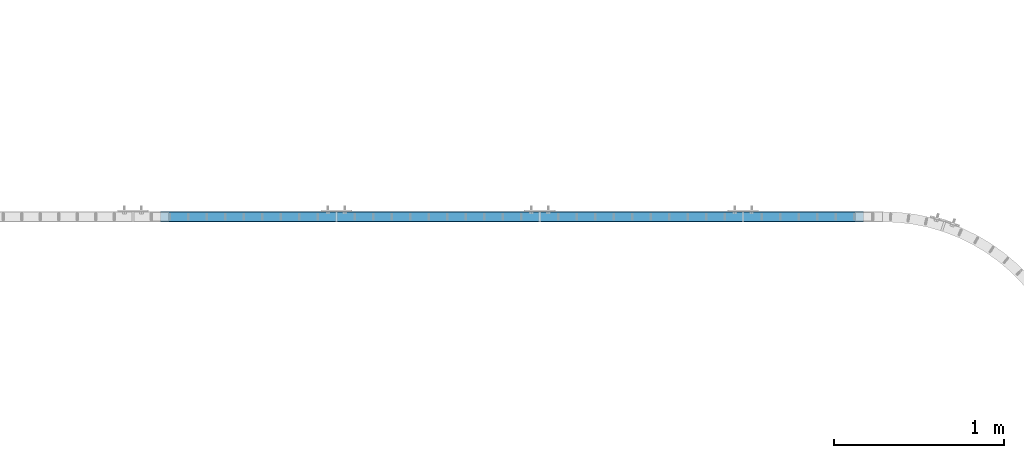
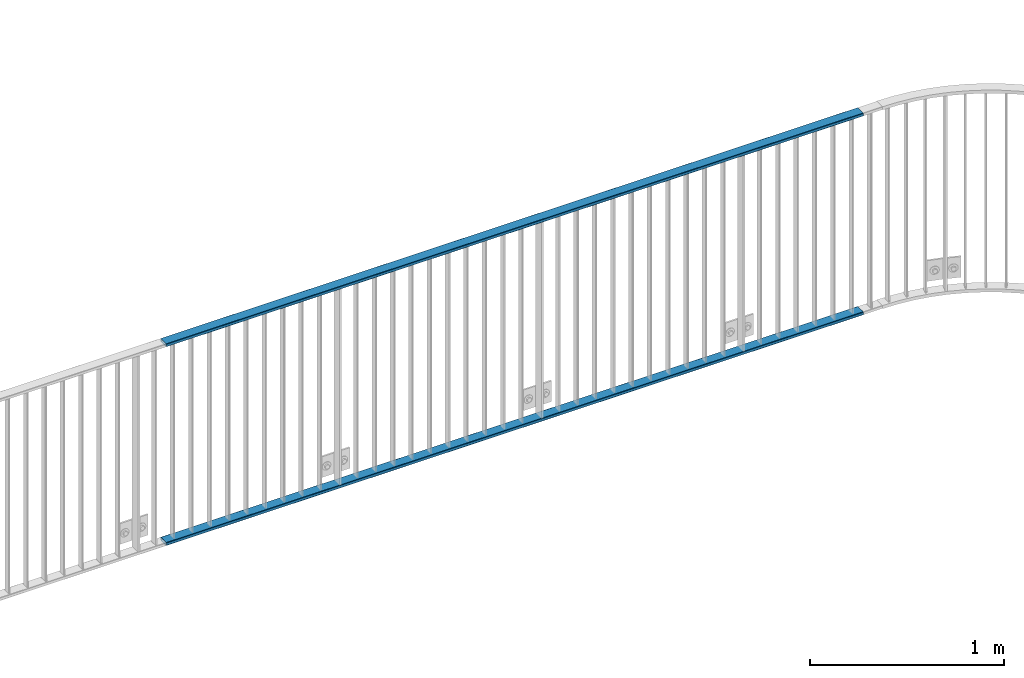
# One storey, part 9 of 156: 2 beams, 1 element without a shape of its own.
"""IFC2X3 building model written with IfcOpenShell, lengths in millimetres."""

from ifc_helpers import new_model, si_unit, frame, origin_with_axes, origin_2d_with_axis, place, context, subcontext, project, spatial, hollow_rectangle, extrude, material, type_object, element, aggregate, save


model = new_model("IFC2X3")

# Units and contexts
model_context = context("Model", 3, precision=1e-05, world=origin_with_axes())
body_context = subcontext(model_context, "Body", "Model", "MODEL_VIEW")
ifc_project = project(units=[si_unit("LENGTHUNIT", "METRE", prefix="MILLI"), si_unit("AREAUNIT", "SQUARE_METRE"), si_unit("VOLUMEUNIT", "CUBIC_METRE"), si_unit("MASSUNIT", "GRAM", prefix="KILO"), si_unit("TIMEUNIT", "SECOND"), si_unit("PLANEANGLEUNIT", "RADIAN"), si_unit("SOLIDANGLEUNIT", "STERADIAN"), si_unit("THERMODYNAMICTEMPERATUREUNIT", "DEGREE_CELSIUS"), si_unit("LUMINOUSINTENSITYUNIT", "LUMEN")], contexts=[model_context])

# Site, building, storey
site_placement = place(None, origin_with_axes())
site = spatial("IfcSite", under=ifc_project, at=site_placement, CompositionType="ELEMENT")
building_placement = place(site_placement, origin_with_axes())
building = spatial("IfcBuilding", under=site, at=building_placement, Name="Undefined", CompositionType="ELEMENT")
storey_placement = place(building_placement, origin_with_axes())
storey = spatial("IfcBuildingStorey", under=building, at=storey_placement, Name="Undefined", CompositionType="ELEMENT", Elevation=0.0)

# Assembly, beams
assembly_placement = place(storey_placement, origin_with_axes())
assembly = element("IfcElementAssembly", 1, at=assembly_placement, inside=storey, AssemblyPlace="NOTDEFINED", PredefinedType="RIGID_FRAME")
ifc_material = material(Name="STEEL/S235JR")
beam_type = type_object("IfcBeamType", Name="K60/20/2", PredefinedType="NOTDEFINED")
beam_1_placement = place(assembly_placement, frame((21563.634999999, 10879.9998016358, 2740.0), z_axis=(0.0, 1.0, 0.0), x_axis=(1.0, 0.0, 0.0)))
beam_1 = element("IfcBeam", 2, at=beam_1_placement, type_object=beam_type, material=ifc_material, ObjectType="K60/20/2", context=body_context, shape_type="SweptSolid", body=[
    extrude(hollow_rectangle(XDim=20.0, YDim=60.0, WallThickness=2.0, InnerFilletRadius=2.0, OuterFilletRadius=4.0, at=origin_2d_with_axis()), frame((4145.45, 0.0, 0.0), z_axis=(-1.0, 0.0, 0.0), x_axis=(0.0, -1.0, 0.0)), (0.0, 0.0, 1.0), 4145.45),
])
beam_2_placement = place(assembly_placement, frame((21563.634999999, 10879.9998016358, 3990.0), z_axis=(0.0, 1.0, 0.0), x_axis=(1.0, 0.0, 0.0)))
beam_2 = element("IfcBeam", 3, at=beam_2_placement, type_object=beam_type, material=ifc_material, ObjectType="K60/20/2", context=body_context, shape_type="SweptSolid", body=[
    extrude(hollow_rectangle(XDim=20.0, YDim=60.0, WallThickness=2.0, InnerFilletRadius=2.0, OuterFilletRadius=4.0, at=origin_2d_with_axis()), frame((4145.45, 0.0, 0.0), z_axis=(-1.0, 0.0, 0.0), x_axis=(0.0, -1.0, 0.0)), (0.0, 0.0, 1.0), 4145.45),
])
aggregate(assembly, [beam_1, beam_2])

save(model, "model.ifc")
